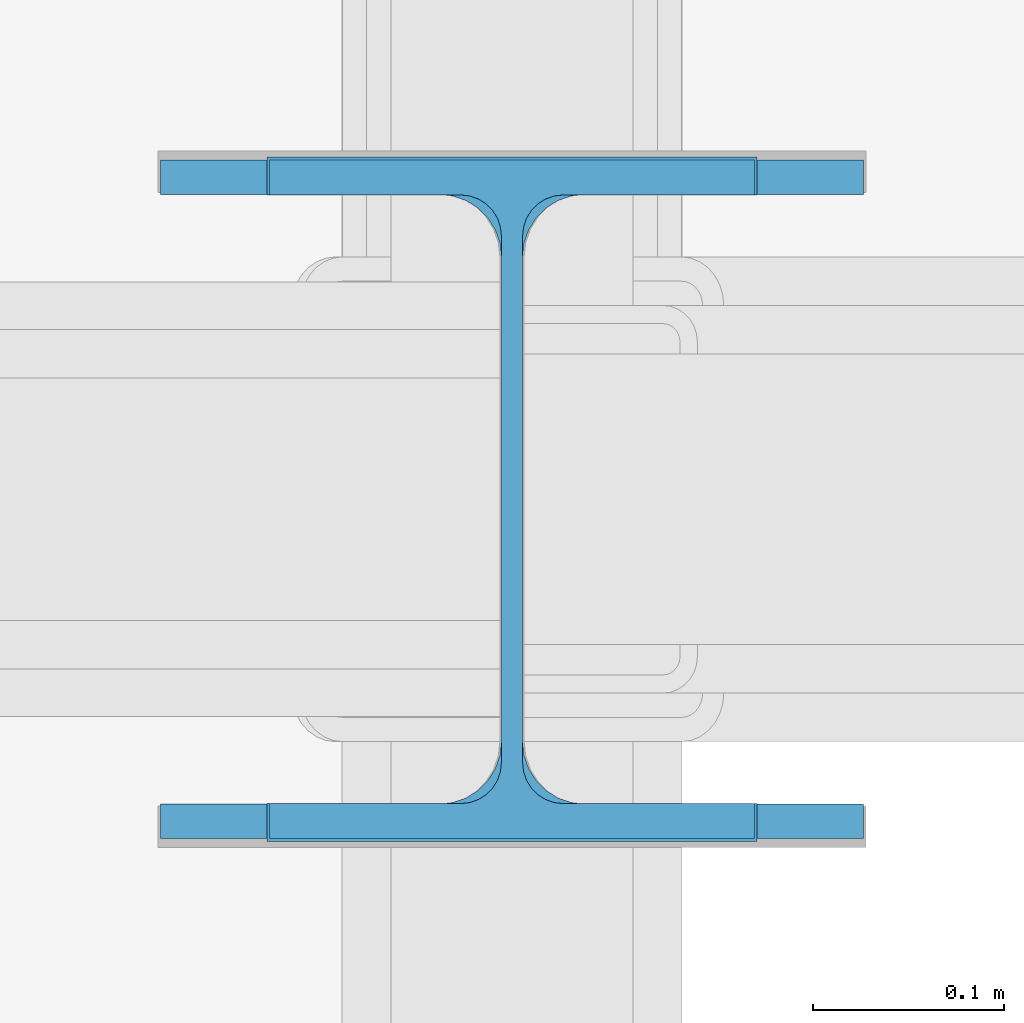
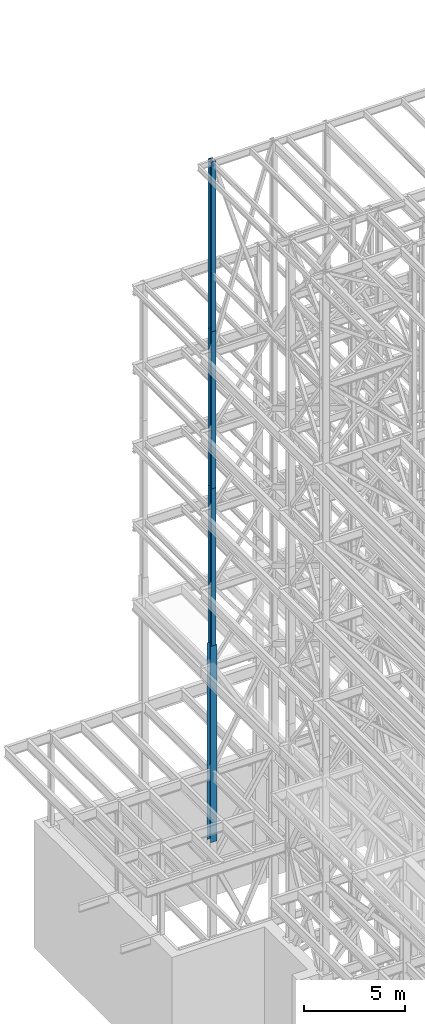
# One storey, part 51 of 150: 4 columns.
"""IFC2X3 building model written with IfcOpenShell, lengths in millimetres."""

from ifc_helpers import new_model, si_unit, frame, origin_with_axes, origin_2d_with_axis, place, context, subcontext, project, spatial, i_section, extrude, material, type_object, element, save


model = new_model("IFC2X3")

# Units and contexts
model_context = context("Model", 3, precision=1e-05, world=origin_with_axes())
body_context = subcontext(model_context, "Body", "Model", "MODEL_VIEW")
ifc_project = project(units=[si_unit("LENGTHUNIT", "METRE", prefix="MILLI"), si_unit("AREAUNIT", "SQUARE_METRE"), si_unit("VOLUMEUNIT", "CUBIC_METRE"), si_unit("MASSUNIT", "GRAM", prefix="KILO"), si_unit("TIMEUNIT", "SECOND"), si_unit("PLANEANGLEUNIT", "RADIAN"), si_unit("SOLIDANGLEUNIT", "STERADIAN"), si_unit("THERMODYNAMICTEMPERATUREUNIT", "DEGREE_CELSIUS"), si_unit("LUMINOUSINTENSITYUNIT", "LUMEN")], contexts=[model_context])

# Site, building, storey
site_placement = place(None, origin_with_axes())
site = spatial("IfcSite", under=ifc_project, at=site_placement, CompositionType="ELEMENT")
building_placement = place(site_placement, origin_with_axes())
building = spatial("IfcBuilding", under=site, at=building_placement, Name="Undefined", CompositionType="ELEMENT")
storey_placement = place(building_placement, origin_with_axes())
storey = spatial("IfcBuildingStorey", under=building, at=storey_placement, Name="Undefined", CompositionType="ELEMENT", Elevation=0.0)

# Columns
ifc_material = material(Name="STEEL/A992")
column_type_1 = type_object("IfcColumnType", Name="W14X68", PredefinedType="NOTDEFINED")
column_1_placement = place(storey_placement, frame((5283.2, 32131.0, 55702.2), z_axis=(0.0, 0.0, 1.0), x_axis=(1.0, 0.0, 0.0)))
element("IfcColumn", 1, at=column_1_placement, inside=storey, type_object=column_type_1, material=ifc_material, Name="COLUMN", ObjectType="W14X68", context=body_context, shape_type="SweptSolid", body=[
    extrude(i_section(OverallWidth=254.0, OverallDepth=355.6, WebThickness=11.1125, FlangeThickness=18.288, FilletRadius=21.3994, at=origin_2d_with_axis()), frame((0.0, 0.0, 10210.8), z_axis=(0.0, 0.0, -1.0), x_axis=(-1.0, 0.0, 0.0)), (0.0, 0.0, 1.0), 10210.8),
])
column_type_2 = type_object("IfcColumnType", Name="W14X90", PredefinedType="NOTDEFINED")
column_2_placement = place(storey_placement, frame((5283.2, 32131.0, 24993.6), z_axis=(0.0, 0.0, 1.0), x_axis=(1.0, 0.0, 0.0)))
element("IfcColumn", 2, at=column_2_placement, inside=storey, type_object=column_type_2, material=ifc_material, Name="COLUMN", ObjectType="W14X90", context=body_context, shape_type="SweptSolid", body=[
    extrude(i_section(OverallWidth=368.3, OverallDepth=355.6, WebThickness=11.1125, FlangeThickness=18.034, FilletRadius=32.7659, at=origin_2d_with_axis()), frame((0.0, 0.0, 11811.0), z_axis=(0.0, 0.0, -1.0), x_axis=(-1.0, 0.0, 0.0)), (0.0, 0.0, 1.0), 11811.0),
])
column_type_3 = type_object("IfcColumnType", Name="W14X74", PredefinedType="NOTDEFINED")
for number, where, z_axis, x_axis, name in (
    (3, (5283.2, 32131.0, 46253.4), (0.0, 0.0, 1.0), (1.0, 0.0, 0.0), "COLUMN"),
    (4, (5283.2, 32131.0, 36804.6), (0.0, 0.0, 1.0), (1.0, 0.0, 0.0), "COLUMN"),
):
    element("IfcColumn", number, at=place(storey_placement, frame(where, z_axis=z_axis, x_axis=x_axis)), inside=storey, type_object=column_type_3, material=ifc_material, Name=name, ObjectType="W14X74", context=body_context, shape_type="SweptSolid", body=[
        extrude(i_section(OverallWidth=256.54, OverallDepth=358.775, WebThickness=11.1125, FlangeThickness=19.939, FilletRadius=21.336, at=origin_2d_with_axis()), frame((0.0, 0.0, 9448.8), z_axis=(0.0, 0.0, -1.0), x_axis=(-1.0, 0.0, 0.0)), (0.0, 0.0, 1.0), 9448.8),
    ])

save(model, "model.ifc")
